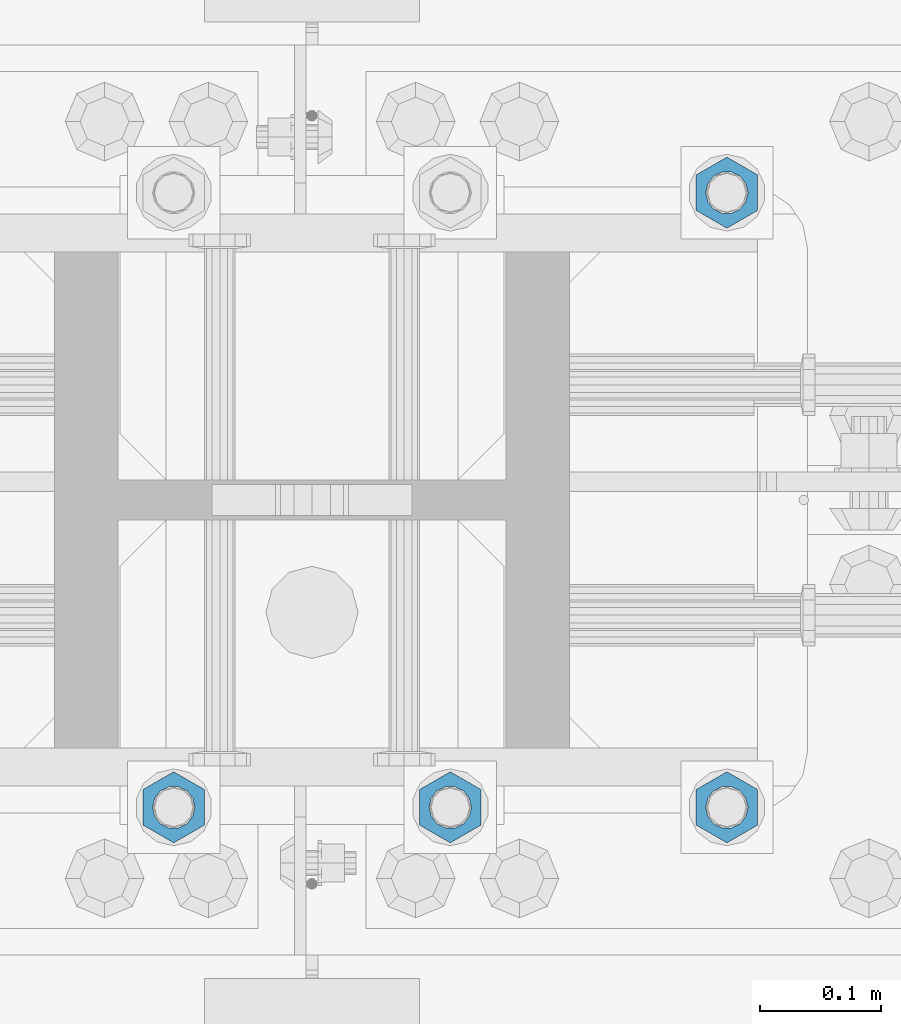
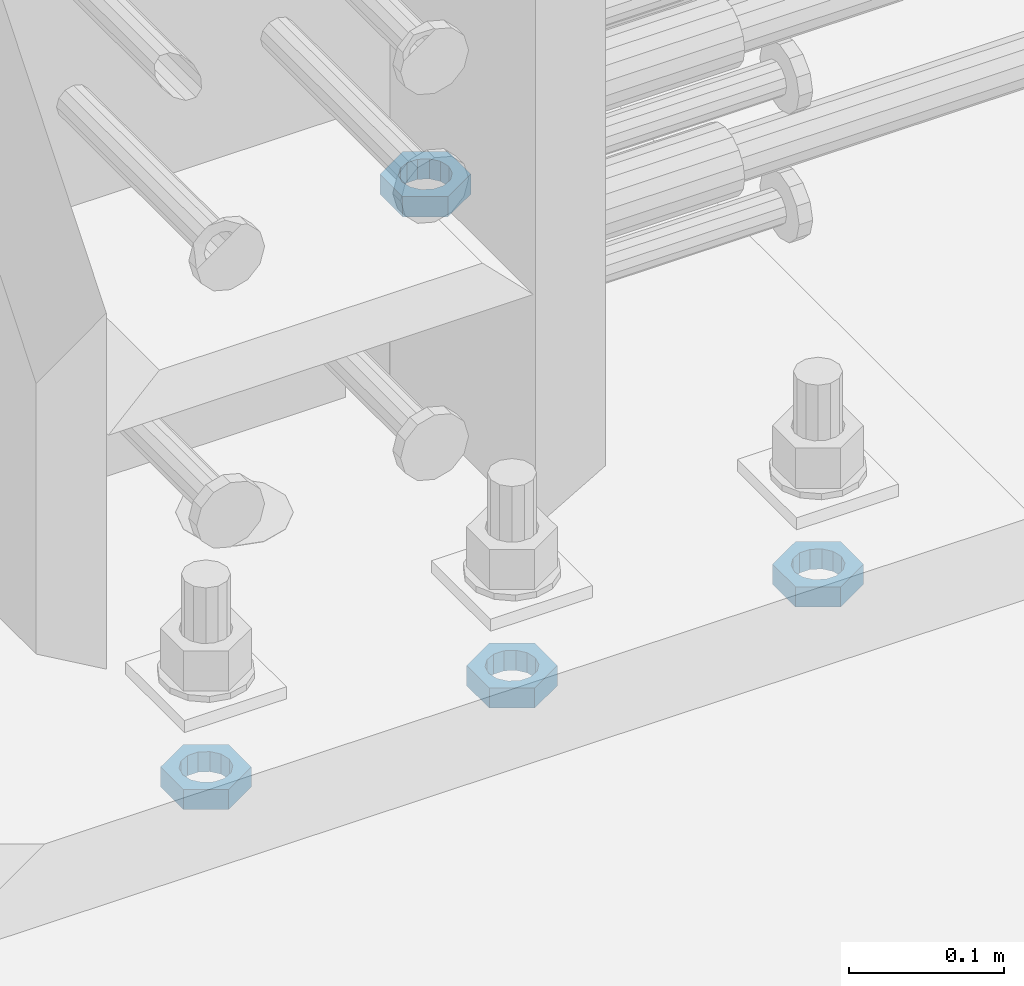
# One storey, part 1396 of 1763: 4 beams, 1 element without a shape of its own.
"""IFC2X3 building model written with IfcOpenShell, lengths in millimetres."""

from ifc_helpers import new_model, si_unit, frame, origin_with_axes, place, context, subcontext, project, spatial, faceted_brep, material, type_object, element, aggregate, save


model = new_model("IFC2X3")

# Units and contexts
model_context = context("Model", 3, precision=1e-05, world=origin_with_axes())
body_context = subcontext(model_context, "Body", "Model", "MODEL_VIEW")
ifc_project = project(units=[si_unit("LENGTHUNIT", "METRE", prefix="MILLI"), si_unit("AREAUNIT", "SQUARE_METRE"), si_unit("VOLUMEUNIT", "CUBIC_METRE"), si_unit("MASSUNIT", "GRAM", prefix="KILO"), si_unit("TIMEUNIT", "SECOND"), si_unit("PLANEANGLEUNIT", "RADIAN"), si_unit("SOLIDANGLEUNIT", "STERADIAN"), si_unit("THERMODYNAMICTEMPERATUREUNIT", "DEGREE_CELSIUS"), si_unit("LUMINOUSINTENSITYUNIT", "LUMEN")], contexts=[model_context])

# Site, building, storey
site_placement = place(None, origin_with_axes())
site = spatial("IfcSite", under=ifc_project, at=site_placement, CompositionType="ELEMENT")
building_placement = place(site_placement, origin_with_axes())
building = spatial("IfcBuilding", under=site, at=building_placement, Name="Undefined", CompositionType="ELEMENT")
storey_placement = place(building_placement, origin_with_axes())
storey = spatial("IfcBuildingStorey", under=building, at=storey_placement, Name="Undefined", CompositionType="ELEMENT", Elevation=0.0)

# Assembly, beams
assembly_placement = place(storey_placement, origin_with_axes())
assembly = element("IfcElementAssembly", 1, at=assembly_placement, inside=storey, Name="TEMPLATE", AssemblyPlace="NOTDEFINED", PredefinedType="RIGID_FRAME")
ifc_material = material(Name="STEEL/A563")
beam_type = type_object("IfcBeamType", Name="1-1/4_DIA. HALF_NUT", PredefinedType="NOTDEFINED")
beam_1_placement = place(assembly_placement, frame((-49059.5372736986, 711.200000000002, 3848.1), z_axis=(-1.0, 0.0, 0.0), x_axis=(0.0, 0.0, -1.0)))
beam_1 = element("IfcBeam", 2, at=beam_1_placement, type_object=beam_type, material=ifc_material, Name="NUT", ObjectType="1-1/4_DIA. HALF_NUT", context=body_context, shape_type="Brep", body=[
    faceted_brep([(0.0, -29.3700008392334, 0.0), (0.0, -14.6800003051758, -25.4300003051758), (15.875, -14.6800003051758, -25.4300003051758), (15.875, -29.3700008392334, 0.0), (0.0, 14.6800003051758, -25.4300003051758), (15.875, 14.6800003051758, -25.4300003051758), (0.0, 29.3700008392334, 0.0), (15.875, 29.3700008392334, 0.0), (0.0, 14.6800003051758, 25.4300003051758), (15.875, 14.6800003051758, 25.4300003051758), (0.0, -14.6800003051758, 25.4300003051758), (15.875, -14.6800003051758, 25.4300003051758), (0.0, 0.0, 17.4599990844727), (0.0, 7.57560968776022, 15.730915608714), (15.875, 7.57560968776022, 15.730915608714), (15.875, 0.0, 17.4599990844727), (0.0, 13.6507769681037, 10.8861313696252), (15.875, 13.6507769681037, 10.8861313696252), (0.0, 17.0222404541215, 3.88521530314756), (15.875, 17.0222404541215, 3.88521530314756), (0.0, 17.0222404541215, -3.88521530314756), (15.875, 17.0222404541215, -3.88521530314756), (0.0, 13.6507769681037, -10.8861313696252), (15.875, 13.6507769681037, -10.8861313696252), (0.0, 7.57560968776022, -15.730915608714), (15.875, 7.57560968776022, -15.730915608714), (0.0, 0.0, -17.4599990844727), (15.875, 0.0, -17.4599990844727), (0.0, -7.57560968776022, -15.730915608714), (15.875, -7.57560968776022, -15.730915608714), (0.0, -13.6507769681037, -10.8861313696252), (15.875, -13.6507769681037, -10.8861313696252), (0.0, -17.0222404541215, -3.88521530314756), (15.875, -17.0222404541215, -3.88521530314756), (0.0, -17.0222404541215, 3.88521530314756), (15.875, -17.0222404541215, 3.88521530314756), (0.0, -13.6507769681037, 10.8861313696252), (15.875, -13.6507769681037, 10.8861313696252), (0.0, -7.57560968776022, 15.730915608714), (15.875, -7.57560968776022, 15.730915608714)], [[[0, 1, 2, 3]], [[1, 4, 5, 2]], [[4, 6, 7, 5]], [[6, 8, 9, 7]], [[8, 10, 11, 9]], [[10, 0, 3, 11]], [[12, 13, 14, 15]], [[13, 16, 17, 14]], [[16, 18, 19, 17]], [[18, 20, 21, 19]], [[20, 22, 23, 21]], [[22, 24, 25, 23]], [[24, 26, 27, 25]], [[26, 28, 29, 27]], [[28, 30, 31, 29]], [[30, 32, 33, 31]], [[32, 34, 35, 33]], [[34, 36, 37, 35]], [[36, 38, 39, 37]], [[38, 12, 15, 39]], [[5, 7, 9, 11, 3, 2], [17, 19, 21, 23, 25, 27, 29, 31, 33, 35, 37, 39, 15, 14]], [[10, 8, 6, 4, 1, 0], [38, 36, 34, 32, 30, 28, 26, 24, 22, 20, 18, 16, 13, 12]]]),
])
beam_2_placement = place(assembly_placement, frame((-49516.7372736986, 203.200000000003, 3848.1), z_axis=(1.0, 0.0, 0.0), x_axis=(0.0, 0.0, -1.0)))
beam_2 = element("IfcBeam", 3, at=beam_2_placement, type_object=beam_type, material=ifc_material, Name="NUT", ObjectType="1-1/4_DIA. HALF_NUT", context=body_context, shape_type="Brep", body=[
    faceted_brep([(0.0, -29.3700008392334, 0.0), (0.0, -14.6800003051758, -25.4300003051758), (15.875, -14.6800003051758, -25.4300003051758), (15.875, -29.3700008392334, 0.0), (0.0, 14.6800003051758, -25.4300003051758), (15.875, 14.6800003051758, -25.4300003051758), (0.0, 29.3700008392334, 0.0), (15.875, 29.3700008392334, 0.0), (0.0, 14.6800003051758, 25.4300003051758), (15.875, 14.6800003051758, 25.4300003051758), (0.0, -14.6800003051758, 25.4300003051758), (15.875, -14.6800003051758, 25.4300003051758), (0.0, 0.0, 17.4599990844727), (0.0, 7.57560968776022, 15.730915608714), (15.875, 7.57560968776022, 15.730915608714), (15.875, 0.0, 17.4599990844727), (0.0, 13.6507769681037, 10.8861313696252), (15.875, 13.6507769681037, 10.8861313696252), (0.0, 17.0222404541215, 3.88521530314756), (15.875, 17.0222404541215, 3.88521530314756), (0.0, 17.0222404541215, -3.88521530314756), (15.875, 17.0222404541215, -3.88521530314756), (0.0, 13.6507769681037, -10.8861313696252), (15.875, 13.6507769681037, -10.8861313696252), (0.0, 7.57560968776022, -15.730915608714), (15.875, 7.57560968776022, -15.730915608714), (0.0, 0.0, -17.4599990844727), (15.875, 0.0, -17.4599990844727), (0.0, -7.57560968776022, -15.730915608714), (15.875, -7.57560968776022, -15.730915608714), (0.0, -13.6507769681037, -10.8861313696252), (15.875, -13.6507769681037, -10.8861313696252), (0.0, -17.0222404541215, -3.88521530314756), (15.875, -17.0222404541215, -3.88521530314756), (0.0, -17.0222404541215, 3.88521530314756), (15.875, -17.0222404541215, 3.88521530314756), (0.0, -13.6507769681037, 10.8861313696252), (15.875, -13.6507769681037, 10.8861313696252), (0.0, -7.57560968776022, 15.730915608714), (15.875, -7.57560968776022, 15.730915608714)], [[[0, 1, 2, 3]], [[1, 4, 5, 2]], [[4, 6, 7, 5]], [[6, 8, 9, 7]], [[8, 10, 11, 9]], [[10, 0, 3, 11]], [[12, 13, 14, 15]], [[13, 16, 17, 14]], [[16, 18, 19, 17]], [[18, 20, 21, 19]], [[20, 22, 23, 21]], [[22, 24, 25, 23]], [[24, 26, 27, 25]], [[26, 28, 29, 27]], [[28, 30, 31, 29]], [[30, 32, 33, 31]], [[32, 34, 35, 33]], [[34, 36, 37, 35]], [[36, 38, 39, 37]], [[38, 12, 15, 39]], [[5, 7, 9, 11, 3, 2], [17, 19, 21, 23, 25, 27, 29, 31, 33, 35, 37, 39, 15, 14]], [[10, 8, 6, 4, 1, 0], [38, 36, 34, 32, 30, 28, 26, 24, 22, 20, 18, 16, 13, 12]]]),
])
beam_3_placement = place(assembly_placement, frame((-49288.1372736986, 203.200000000003, 3848.1), z_axis=(1.0, 0.0, 0.0), x_axis=(0.0, 0.0, -1.0)))
beam_3 = element("IfcBeam", 4, at=beam_3_placement, type_object=beam_type, material=ifc_material, Name="NUT", ObjectType="1-1/4_DIA. HALF_NUT", context=body_context, shape_type="Brep", body=[
    faceted_brep([(0.0, -29.3700008392334, 0.0), (0.0, -14.6800003051758, -25.4300003051758), (15.875, -14.6800003051758, -25.4300003051758), (15.875, -29.3700008392334, 0.0), (0.0, 14.6800003051758, -25.4300003051758), (15.875, 14.6800003051758, -25.4300003051758), (0.0, 29.3700008392334, 0.0), (15.875, 29.3700008392334, 0.0), (0.0, 14.6800003051758, 25.4300003051758), (15.875, 14.6800003051758, 25.4300003051758), (0.0, -14.6800003051758, 25.4300003051758), (15.875, -14.6800003051758, 25.4300003051758), (0.0, 0.0, 17.4599990844727), (0.0, 7.57560968776022, 15.730915608714), (15.875, 7.57560968776022, 15.730915608714), (15.875, 0.0, 17.4599990844727), (0.0, 13.6507769681037, 10.8861313696252), (15.875, 13.6507769681037, 10.8861313696252), (0.0, 17.0222404541215, 3.88521530314756), (15.875, 17.0222404541215, 3.88521530314756), (0.0, 17.0222404541215, -3.88521530314756), (15.875, 17.0222404541215, -3.88521530314756), (0.0, 13.6507769681037, -10.8861313696252), (15.875, 13.6507769681037, -10.8861313696252), (0.0, 7.57560968776022, -15.730915608714), (15.875, 7.57560968776022, -15.730915608714), (0.0, 0.0, -17.4599990844727), (15.875, 0.0, -17.4599990844727), (0.0, -7.57560968776022, -15.730915608714), (15.875, -7.57560968776022, -15.730915608714), (0.0, -13.6507769681037, -10.8861313696252), (15.875, -13.6507769681037, -10.8861313696252), (0.0, -17.0222404541215, -3.88521530314756), (15.875, -17.0222404541215, -3.88521530314756), (0.0, -17.0222404541215, 3.88521530314756), (15.875, -17.0222404541215, 3.88521530314756), (0.0, -13.6507769681037, 10.8861313696252), (15.875, -13.6507769681037, 10.8861313696252), (0.0, -7.57560968776022, 15.730915608714), (15.875, -7.57560968776022, 15.730915608714)], [[[0, 1, 2, 3]], [[1, 4, 5, 2]], [[4, 6, 7, 5]], [[6, 8, 9, 7]], [[8, 10, 11, 9]], [[10, 0, 3, 11]], [[12, 13, 14, 15]], [[13, 16, 17, 14]], [[16, 18, 19, 17]], [[18, 20, 21, 19]], [[20, 22, 23, 21]], [[22, 24, 25, 23]], [[24, 26, 27, 25]], [[26, 28, 29, 27]], [[28, 30, 31, 29]], [[30, 32, 33, 31]], [[32, 34, 35, 33]], [[34, 36, 37, 35]], [[36, 38, 39, 37]], [[38, 12, 15, 39]], [[5, 7, 9, 11, 3, 2], [17, 19, 21, 23, 25, 27, 29, 31, 33, 35, 37, 39, 15, 14]], [[10, 8, 6, 4, 1, 0], [38, 36, 34, 32, 30, 28, 26, 24, 22, 20, 18, 16, 13, 12]]]),
])
beam_4_placement = place(assembly_placement, frame((-49059.5372736986, 203.200000000003, 3848.1), z_axis=(1.0, 0.0, 0.0), x_axis=(0.0, 0.0, -1.0)))
beam_4 = element("IfcBeam", 5, at=beam_4_placement, type_object=beam_type, material=ifc_material, Name="NUT", ObjectType="1-1/4_DIA. HALF_NUT", context=body_context, shape_type="Brep", body=[
    faceted_brep([(0.0, -29.3700008392334, 0.0), (0.0, -14.6800003051758, -25.4300003051758), (15.875, -14.6800003051758, -25.4300003051758), (15.875, -29.3700008392334, 0.0), (0.0, 14.6800003051758, -25.4300003051758), (15.875, 14.6800003051758, -25.4300003051758), (0.0, 29.3700008392334, 0.0), (15.875, 29.3700008392334, 0.0), (0.0, 14.6800003051758, 25.4300003051758), (15.875, 14.6800003051758, 25.4300003051758), (0.0, -14.6800003051758, 25.4300003051758), (15.875, -14.6800003051758, 25.4300003051758), (0.0, 0.0, 17.4599990844727), (0.0, 7.57560968776022, 15.730915608714), (15.875, 7.57560968776022, 15.730915608714), (15.875, 0.0, 17.4599990844727), (0.0, 13.6507769681037, 10.8861313696252), (15.875, 13.6507769681037, 10.8861313696252), (0.0, 17.0222404541215, 3.88521530314756), (15.875, 17.0222404541215, 3.88521530314756), (0.0, 17.0222404541215, -3.88521530314756), (15.875, 17.0222404541215, -3.88521530314756), (0.0, 13.6507769681037, -10.8861313696252), (15.875, 13.6507769681037, -10.8861313696252), (0.0, 7.57560968776022, -15.730915608714), (15.875, 7.57560968776022, -15.730915608714), (0.0, 0.0, -17.4599990844727), (15.875, 0.0, -17.4599990844727), (0.0, -7.57560968776022, -15.730915608714), (15.875, -7.57560968776022, -15.730915608714), (0.0, -13.6507769681037, -10.8861313696252), (15.875, -13.6507769681037, -10.8861313696252), (0.0, -17.0222404541215, -3.88521530314756), (15.875, -17.0222404541215, -3.88521530314756), (0.0, -17.0222404541215, 3.88521530314756), (15.875, -17.0222404541215, 3.88521530314756), (0.0, -13.6507769681037, 10.8861313696252), (15.875, -13.6507769681037, 10.8861313696252), (0.0, -7.57560968776022, 15.730915608714), (15.875, -7.57560968776022, 15.730915608714)], [[[0, 1, 2, 3]], [[1, 4, 5, 2]], [[4, 6, 7, 5]], [[6, 8, 9, 7]], [[8, 10, 11, 9]], [[10, 0, 3, 11]], [[12, 13, 14, 15]], [[13, 16, 17, 14]], [[16, 18, 19, 17]], [[18, 20, 21, 19]], [[20, 22, 23, 21]], [[22, 24, 25, 23]], [[24, 26, 27, 25]], [[26, 28, 29, 27]], [[28, 30, 31, 29]], [[30, 32, 33, 31]], [[32, 34, 35, 33]], [[34, 36, 37, 35]], [[36, 38, 39, 37]], [[38, 12, 15, 39]], [[5, 7, 9, 11, 3, 2], [17, 19, 21, 23, 25, 27, 29, 31, 33, 35, 37, 39, 15, 14]], [[10, 8, 6, 4, 1, 0], [38, 36, 34, 32, 30, 28, 26, 24, 22, 20, 18, 16, 13, 12]]]),
])
aggregate(assembly, [beam_1, beam_2, beam_3, beam_4])

save(model, "model.ifc")
